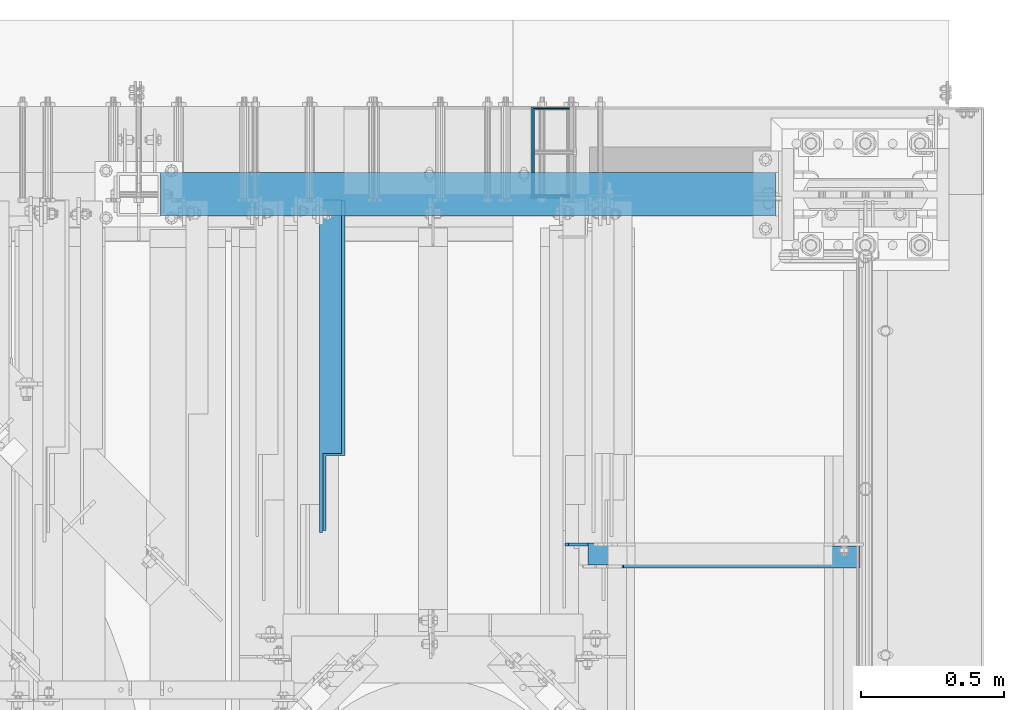
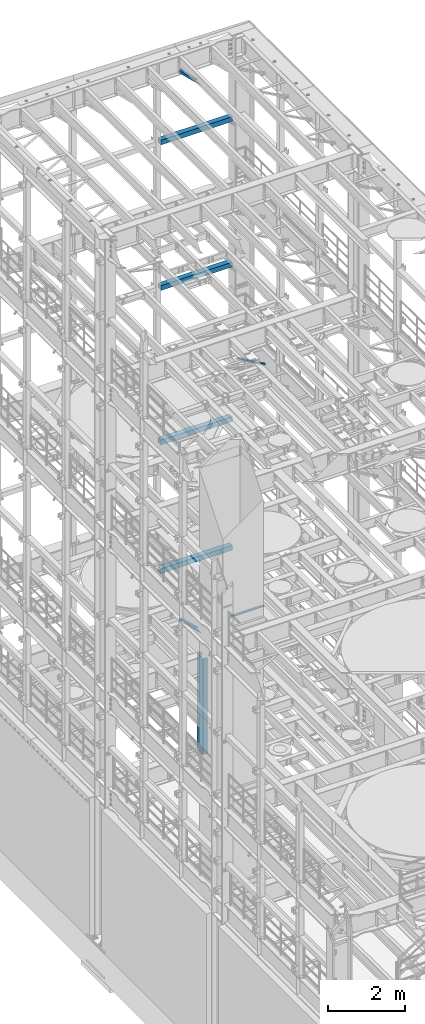
# One storey, part 1070 of 1876: 9 beams, 1 member, 10 elements without a shape of their own.
"""IFC2X3 building model written with IfcOpenShell, lengths in millimetres."""

from ifc_helpers import new_model, si_unit, frame, origin_with_axes, place, context, subcontext, project, spatial, faceted_brep, material, type_object, element, aggregate, save


model = new_model("IFC2X3")

# Units and contexts
model_context = context("Model", 3, precision=1e-05, world=origin_with_axes())
body_context = subcontext(model_context, "Body", "Model", "MODEL_VIEW")
ifc_project = project(units=[si_unit("LENGTHUNIT", "METRE", prefix="MILLI"), si_unit("AREAUNIT", "SQUARE_METRE"), si_unit("VOLUMEUNIT", "CUBIC_METRE"), si_unit("MASSUNIT", "GRAM", prefix="KILO"), si_unit("TIMEUNIT", "SECOND"), si_unit("PLANEANGLEUNIT", "RADIAN"), si_unit("SOLIDANGLEUNIT", "STERADIAN"), si_unit("THERMODYNAMICTEMPERATUREUNIT", "DEGREE_CELSIUS"), si_unit("LUMINOUSINTENSITYUNIT", "LUMEN")], contexts=[model_context])

# Site, building, storey
site_placement = place(None, origin_with_axes())
site = spatial("IfcSite", under=ifc_project, at=site_placement, CompositionType="ELEMENT")
building_placement = place(site_placement, origin_with_axes())
building = spatial("IfcBuilding", under=site, at=building_placement, Name="Undefined", CompositionType="ELEMENT")
storey_placement = place(building_placement, origin_with_axes())
storey = spatial("IfcBuildingStorey", under=building, at=storey_placement, Name="Undefined", CompositionType="ELEMENT", Elevation=0.0)

# Assembly, beam
assembly_1_placement = place(storey_placement, origin_with_axes())
assembly_1 = element("IfcElementAssembly", 1, at=assembly_1_placement, inside=storey, Name="FRAME", AssemblyPlace="NOTDEFINED", PredefinedType="RIGID_FRAME")
ifc_material_1 = material()
beam_type_1 = type_object("IfcBeamType", Name="HSS6X6X3/8", PredefinedType="NOTDEFINED")
beam_1_placement = place(assembly_1_placement, frame((5080.0, 13716.0, 6330.95), z_axis=(0.0, 1.0, 0.0), x_axis=(1.0, 0.0, 0.0)))
beam_1 = element("IfcBeam", 2, at=beam_1_placement, type_object=beam_type_1, material=ifc_material_1, Name="BEAM", ObjectType="HSS6X6X3/8", context=body_context, shape_type="Brep", body=[
    faceted_brep([(76.2000000000007, 66.6749999999993, -66.6750000000002), (76.2000000000007, -66.6749999999993, -66.6750000000002), (2225.675, -66.6750000000002, -66.6749999999993), (2225.675, 66.6750000000002, -66.6749999999993), (76.2000000000007, -66.6749999999993, 66.6750000000002), (2225.675, -66.6750000000002, 66.6749999999993), (76.2000000000007, 66.6749999999993, 66.6750000000002), (2225.675, 66.6750000000002, 66.6749999999993), (76.2000000000007, 76.2000000000007, -76.1999999999998), (76.2000000000007, 76.2000000000007, 76.1999999999998), (2225.675, 76.1999999999998, 76.2000000000007), (2225.675, 76.1999999999998, -76.2000000000007), (76.2000000000007, -76.2000000000007, 76.1999999999998), (2225.675, -76.1999999999998, 76.2000000000007), (76.2000000000007, -76.2000000000007, -76.1999999999998), (2225.675, -76.1999999999998, -76.2000000000007)], [[[0, 1, 2, 3]], [[1, 4, 5, 2]], [[4, 6, 7, 5]], [[6, 0, 3, 7]], [[8, 9, 10, 11]], [[9, 12, 13, 10]], [[12, 14, 15, 13]], [[14, 8, 11, 15]], [[13, 15, 11, 10], [5, 7, 3, 2]], [[14, 12, 9, 8], [6, 4, 1, 0]]]),
])
aggregate(assembly_1, [beam_1])

assembly_2_placement = place(storey_placement, origin_with_axes())
assembly_2 = element("IfcElementAssembly", 3, at=assembly_2_placement, inside=storey, Name="FRAME", AssemblyPlace="NOTDEFINED", PredefinedType="RIGID_FRAME")
beam_2_placement = place(assembly_2_placement, frame((5080.0, 13716.0, 19958.05), z_axis=(0.0, 1.0, 0.0), x_axis=(1.0, 0.0, 0.0)))
beam_2 = element("IfcBeam", 4, at=beam_2_placement, type_object=beam_type_1, material=ifc_material_1, Name="BEAM", ObjectType="HSS6X6X3/8", context=body_context, shape_type="Brep", body=[
    faceted_brep([(76.2000000000007, 66.6749999999993, -66.6750000000002), (76.2000000000007, -66.6749999999993, -66.6750000000002), (2225.675, -66.6750000000002, -66.6749999999993), (2225.675, 66.6750000000002, -66.6749999999993), (76.2000000000007, -66.6749999999993, 66.6750000000002), (2225.675, -66.6750000000002, 66.6749999999993), (76.2000000000007, 66.6749999999993, 66.6750000000002), (2225.675, 66.6750000000002, 66.6749999999993), (76.2000000000007, 76.2000000000007, -76.1999999999998), (76.2000000000007, 76.2000000000007, 76.1999999999998), (2225.675, 76.1999999999998, 76.2000000000007), (2225.675, 76.1999999999998, -76.2000000000007), (76.2000000000007, -76.2000000000007, 76.1999999999998), (2225.675, -76.1999999999998, 76.2000000000007), (76.2000000000007, -76.2000000000007, -76.1999999999998), (2225.675, -76.1999999999998, -76.2000000000007)], [[[0, 1, 2, 3]], [[1, 4, 5, 2]], [[4, 6, 7, 5]], [[6, 0, 3, 7]], [[8, 9, 10, 11]], [[9, 12, 13, 10]], [[12, 14, 15, 13]], [[14, 8, 11, 15]], [[13, 15, 11, 10], [5, 7, 3, 2]], [[14, 12, 9, 8], [6, 4, 1, 0]]]),
])
aggregate(assembly_2, [beam_2])

assembly_3_placement = place(storey_placement, origin_with_axes())
assembly_3 = element("IfcElementAssembly", 5, at=assembly_3_placement, inside=storey, Name="FRAME", AssemblyPlace="NOTDEFINED", PredefinedType="RIGID_FRAME")
beam_3_placement = place(assembly_3_placement, frame((5080.0, 13716.0, 15335.25), z_axis=(0.0, 1.0, 0.0), x_axis=(1.0, 0.0, 0.0)))
beam_3 = element("IfcBeam", 6, at=beam_3_placement, type_object=beam_type_1, material=ifc_material_1, Name="BEAM", ObjectType="HSS6X6X3/8", context=body_context, shape_type="Brep", body=[
    faceted_brep([(76.2000000000007, 66.6749999999993, -66.6750000000002), (76.2000000000007, -66.6749999999993, -66.6750000000002), (2225.675, -66.6750000000002, -66.6749999999993), (2225.675, 66.6750000000002, -66.6749999999993), (76.2000000000007, -66.6749999999993, 66.6750000000002), (2225.675, -66.6750000000002, 66.6749999999993), (76.2000000000007, 66.6749999999993, 66.6750000000002), (2225.675, 66.6750000000002, 66.6749999999993), (76.2000000000007, 76.2000000000007, -76.1999999999998), (76.2000000000007, 76.2000000000007, 76.1999999999998), (2225.675, 76.1999999999998, 76.2000000000007), (2225.675, 76.1999999999998, -76.2000000000007), (76.2000000000007, -76.2000000000007, 76.1999999999998), (2225.675, -76.1999999999998, 76.2000000000007), (76.2000000000007, -76.2000000000007, -76.1999999999998), (2225.675, -76.1999999999998, -76.2000000000007)], [[[0, 1, 2, 3]], [[1, 4, 5, 2]], [[4, 6, 7, 5]], [[6, 0, 3, 7]], [[8, 9, 10, 11]], [[9, 12, 13, 10]], [[12, 14, 15, 13]], [[14, 8, 11, 15]], [[13, 15, 11, 10], [5, 7, 3, 2]], [[14, 12, 9, 8], [6, 4, 1, 0]]]),
])
aggregate(assembly_3, [beam_3])

assembly_4_placement = place(storey_placement, origin_with_axes())
assembly_4 = element("IfcElementAssembly", 7, at=assembly_4_placement, inside=storey, Name="FRAME", AssemblyPlace="NOTDEFINED", PredefinedType="RIGID_FRAME")
beam_4_placement = place(assembly_4_placement, frame((5080.0, 13716.0, 10420.35), z_axis=(0.0, 1.0, 0.0), x_axis=(1.0, 0.0, 0.0)))
beam_4 = element("IfcBeam", 8, at=beam_4_placement, type_object=beam_type_1, material=ifc_material_1, Name="BEAM", ObjectType="HSS6X6X3/8", context=body_context, shape_type="Brep", body=[
    faceted_brep([(76.2000000000007, 66.6749999999993, -66.6750000000002), (76.2000000000007, -66.6749999999993, -66.6750000000002), (2225.675, -66.6750000000002, -66.6749999999993), (2225.675, 66.6750000000002, -66.6749999999993), (76.2000000000007, -66.6749999999993, 66.6750000000002), (2225.675, -66.6750000000002, 66.6749999999993), (76.2000000000007, 66.6749999999993, 66.6750000000002), (2225.675, 66.6750000000002, 66.6749999999993), (76.2000000000007, 76.2000000000007, -76.1999999999998), (76.2000000000007, 76.2000000000007, 76.1999999999998), (2225.675, 76.1999999999998, 76.2000000000007), (2225.675, 76.1999999999998, -76.2000000000007), (76.2000000000007, -76.2000000000007, 76.1999999999998), (2225.675, -76.1999999999998, 76.2000000000007), (76.2000000000007, -76.2000000000007, -76.1999999999998), (2225.675, -76.1999999999998, -76.2000000000007)], [[[0, 1, 2, 3]], [[1, 4, 5, 2]], [[4, 6, 7, 5]], [[6, 0, 3, 7]], [[8, 9, 10, 11]], [[9, 12, 13, 10]], [[12, 14, 15, 13]], [[14, 8, 11, 15]], [[13, 15, 11, 10], [5, 7, 3, 2]], [[14, 12, 9, 8], [6, 4, 1, 0]]]),
])
aggregate(assembly_4, [beam_4])

# Assembly, member
assembly_5_placement = place(storey_placement, origin_with_axes())
assembly_5 = element("IfcElementAssembly", 9, at=assembly_5_placement, inside=storey, Name="BRACE", AssemblyPlace="NOTDEFINED", PredefinedType="RIGID_FRAME")
ifc_material_2 = material(Name="STEEL/A36")
member_type = type_object("IfcMemberType", Name="L3X3X3/8", PredefinedType="NOTDEFINED")
member_placement = place(assembly_5_placement, frame((6673.56288393271, 12449.175, 13302.1718727092), z_axis=(0.0, -1.0, 0.0), x_axis=(0.861630637805759, 0.0, -0.507535854885584)))
member = element("IfcMember", 10, at=member_placement, type_object=member_type, material=ifc_material_2, Name="BRACE", ObjectType="L3X3X3/8", context=body_context, shape_type="Brep", body=[
    faceted_brep([(93.8357350541173, 38.0999999999913, -38.0999999999999), (93.8357350541173, 38.0999999999913, 38.0999999999999), (1052.95263444459, 38.0999999997257, 38.0999999999999), (1052.95263444459, 38.0999999997257, -38.0999999999999), (93.8357350541228, 28.5749999999862, 38.0999999999999), (1052.95263444459, 28.5749999997206, 38.0999999999999), (93.8357350541228, 28.5749999999862, -28.5749999999998), (1052.95263444459, 28.5749999997206, -28.5749999999998), (93.8357350541537, -38.100000000044, -28.5749999999998), (1052.95263444462, -38.100000000306, -28.5749999999998), (93.8357350541537, -38.100000000044, -38.0999999999999), (1052.95263444462, -38.100000000306, -38.0999999999999)], [[[0, 1, 2, 3]], [[1, 4, 5, 2]], [[4, 6, 7, 5]], [[6, 8, 9, 7]], [[8, 10, 11, 9]], [[10, 0, 3, 11]], [[5, 7, 9, 11, 3, 2]], [[10, 8, 6, 4, 1, 0]]]),
])
aggregate(assembly_5, [member])

# Assembly, beam
assembly_6_placement = place(storey_placement, origin_with_axes())
assembly_6 = element("IfcElementAssembly", 11, at=assembly_6_placement, inside=storey, AssemblyPlace="NOTDEFINED", PredefinedType="RIGID_FRAME")
beam_type_2 = type_object("IfcBeamType", Name="L3X3X3/8", PredefinedType="NOTDEFINED")
beam_5_placement = place(assembly_6_placement, frame((5762.62500009537, 12830.5843372416, 4789.15168871849), z_axis=(1.0, 0.0, 0.0), x_axis=(0.0, 0.967147277703794, -0.254216724922142)))
beam_5 = element("IfcBeam", 12, at=beam_5_placement, type_object=beam_type_2, material=ifc_material_2, ObjectType="L3X3X3/8", context=body_context, shape_type="Brep", body=[
    faceted_brep([(0.0, 38.1000000000004, -38.1), (0.0, 38.1000000000004, 38.1), (881.684520949349, 38.1000000001804, 38.1000000000004), (881.684520949349, 38.1000000001804, -38.1000000000004), (-36.2371036914428, 28.5749999999935, 38.1000000000004), (881.696433462228, 28.5750000001808, 38.1000000000004), (-36.2371036914428, 28.5749999999935, -28.5749999999998), (881.696433462228, 28.5750000001808, -28.5749999999998), (-289.896829504256, -38.1000000000595, -28.5749999999998), (881.779821052378, -38.0999999998203, -28.5749999999998), (-289.896829504256, -38.1000000000595, -38.1000000000004), (881.779821052378, -38.0999999998203, -38.1000000000004)], [[[0, 1, 2, 3]], [[1, 4, 5, 2]], [[4, 6, 7, 5]], [[6, 8, 9, 7]], [[8, 10, 11, 9]], [[10, 0, 3, 11]], [[5, 7, 9, 11, 3, 2]], [[10, 8, 6, 4, 1, 0]]]),
])
aggregate(assembly_6, [beam_5])

assembly_7_placement = place(storey_placement, origin_with_axes())
assembly_7 = element("IfcElementAssembly", 13, at=assembly_7_placement, inside=storey, AssemblyPlace="NOTDEFINED", PredefinedType="RIGID_FRAME")
beam_6_placement = place(assembly_7_placement, frame((5749.925, 12840.8509533049, 22213.431722183), z_axis=(1.0, 0.0, 0.0), x_axis=(0.0, 0.970296005691371, -0.241920774923053)))
beam_6 = element("IfcBeam", 14, at=beam_6_placement, type_object=beam_type_2, material=ifc_material_2, ObjectType="L3X3X3/8", context=body_context, shape_type="Brep", body=[
    faceted_brep([(0.0, 38.1000000000004, -38.1), (0.0, 38.1000000000004, 38.1), (871.989692018896, 38.1000000003733, 38.1000000000004), (871.989692018896, 38.1000000003733, -38.1000000000004), (-38.2028763666676, 28.5750000000298, 38.1000000000004), (871.9896920189, 28.5750000003572, 38.1000000000004), (-38.2028763666676, 28.5750000000298, -28.5749999999998), (871.9896920189, 28.5750000003572, -28.5749999999998), (-305.623010913256, -38.1000000001623, -28.5749999999998), (871.989692018928, -38.0999999997366, -28.5749999999998), (-305.623010913256, -38.1000000001623, -38.1000000000004), (871.989692018928, -38.0999999997366, -38.1000000000004)], [[[0, 1, 2, 3]], [[1, 4, 5, 2]], [[4, 6, 7, 5]], [[6, 8, 9, 7]], [[8, 10, 11, 9]], [[10, 0, 3, 11]], [[5, 7, 9, 11, 3, 2]], [[10, 8, 6, 4, 1, 0]]]),
])
aggregate(assembly_7, [beam_6])

assembly_8_placement = place(storey_placement, origin_with_axes())
assembly_8 = element("IfcElementAssembly", 15, at=assembly_8_placement, inside=storey, Name="ANGLE", AssemblyPlace="NOTDEFINED", PredefinedType="RIGID_FRAME")
beam_7_placement = place(assembly_8_placement, frame((6565.9, 12458.7, 5092.7), z_axis=(0.0, -1.0, 0.0), x_axis=(1.0, 0.0, 0.0)))
beam_7 = element("IfcBeam", 16, at=beam_7_placement, type_object=beam_type_2, material=ifc_material_2, Name="ANGLE", ObjectType="L3X3X3/8", context=body_context, shape_type="Brep", body=[
    faceted_brep([(938.213000419482, 28.5750000000007, -28.5749999999998), (938.213001286278, 28.5750000000007, 38.0999999999999), (84.137014014791, 28.5749999999998, 38.1000000000258), (84.1370001605219, 28.5749999999998, -28.5750000000007), (938.213001286278, 38.0999999999985, 38.0999999999999), (84.136999759924, 38.0999999999985, 38.0999999999999), (15.8750004498515, 25.4000000000005, -28.5750000000007), (15.8750002879233, 25.4000000000005, -38.1000000000004), (3.17500047865815, 12.7000001907354, -38.1000000000004), (3.1750006405864, 12.7000001907354, -28.5750000000007), (84.1369986264262, 25.4000000000005, -28.5750000000007), (84.136998464498, 25.4000000000005, -38.1000000000004), (84.1369984645207, 38.0999999999985, -38.0999999999999), (938.213000295654, 38.0999999999985, -38.0999999999999), (938.213000419482, 12.6999992370475, -28.5749999999998), (938.213000295654, 12.6999992370475, -38.0999999999999), (1015.20625603472, 12.6999992370475, -28.5749999999998), (1015.20625591089, 12.6999992370475, -38.0999999999999), (1046.95625603472, -19.0500007629525, -28.5749999999998), (1046.95625591089, -19.0500007629525, -38.0999999999999), (1046.95625011747, -38.0999999999985, -28.5749999999998), (1046.95625011747, -38.0999999999985, -38.0999999999999), (3.17499999075153, -38.0999999999985, -28.5749999999998), (3.17499999075153, -38.0999999999985, -38.0999999999999), (3.17500047865815, -1.52587836055318e-06, -38.1000000000004), (3.1750006405864, -1.52587836055318e-06, -28.5750000000007)], [[[0, 1, 2, 3]], [[1, 4, 5, 2]], [[6, 7, 8, 9]], [[10, 11, 7, 6]], [[2, 5, 12, 11, 10, 3]], [[4, 13, 12, 5]], [[1, 0, 14, 15, 13, 4]], [[16, 17, 15, 14]], [[17, 16, 18, 19]], [[19, 18, 20, 21]], [[22, 23, 21, 20]], [[8, 7, 11, 12, 13, 15, 17, 19, 21, 23, 24]], [[9, 8, 24, 25]], [[20, 18, 16, 14, 0, 3, 10, 6, 9, 25, 22]], [[24, 23, 22, 25]]]),
])
aggregate(assembly_8, [beam_7])

assembly_9_placement = place(storey_placement, origin_with_axes())
assembly_9 = element("IfcElementAssembly", 17, at=assembly_9_placement, inside=storey, Name="BEAM", AssemblyPlace="NOTDEFINED", PredefinedType="REINFORCEMENT_UNIT")
ifc_material_3 = material(Name="CONCRETE/5000")
beam_type_3 = type_object("IfcBeamType", PredefinedType="NOTDEFINED")
beam_8_placement = place(assembly_9_placement, frame((6584.95045001539, 13713.6189938963, 1524.0), z_axis=(0.0, 0.0, 1.0), x_axis=(-1.0, 0.0, 0.0)))
beam_8 = element("IfcBeam", 18, at=beam_8_placement, type_object=beam_type_3, material=ifc_material_3, Name="BEAM", context=body_context, shape_type="Brep", body=[
    faceted_brep([(1.60071067512035e-10, -2.38100000000122, -1524.0), (1.60071067512035e-10, -2.38100000000122, 1524.0), (-1.60071067512035e-10, 2.38099999999758, 1524.0), (-1.60071067512035e-10, 2.38099999999758, -1524.0), (126.999998724466, 2.3810000085341, 1524.0), (126.999998724466, 2.3810000085341, -1524.0), (122.237998962564, -2.38099999178485, -1524.0), (122.237998962564, -2.38099999178485, 1524.0), (127.000013964417, -302.417987546485, 1524.0), (127.000013964417, -302.417987546485, -1524.0), (122.238013726317, -297.655987784585, -1524.0), (122.238013726317, -297.655987784585, 1524.0), (1.50022988236742e-05, -302.417993896486, 1524.0), (1.50022988236742e-05, -302.417993896486, -1524.0), (1.47641985677183e-05, -297.655993896486, 1524.0), (1.47641985677183e-05, -297.655993896486, -1524.0)], [[[0, 1, 2, 3]], [[3, 2, 4, 5]], [[1, 0, 6, 7]], [[5, 4, 8, 9]], [[7, 6, 10, 11]], [[9, 8, 12, 13]], [[8, 4, 2, 1, 7, 11, 14, 12]], [[11, 10, 15, 14]], [[10, 6, 0, 3, 5, 9, 13, 15]], [[14, 15, 13, 12]]]),
])
aggregate(assembly_9, [beam_8])

assembly_10_placement = place(storey_placement, origin_with_axes())
assembly_10 = element("IfcElementAssembly", 19, at=assembly_10_placement, inside=storey, Name="BENT PLATE", AssemblyPlace="NOTDEFINED", PredefinedType="RIGID_FRAME")
beam_type_4 = type_object("IfcBeamType", PredefinedType="NOTDEFINED")
beam_9_placement = place(assembly_10_placement, frame((6584.9504498965, 13706.4754938963, 1524.0), z_axis=(0.0, 0.0, 1.0), x_axis=(-1.0, 0.0, 0.0)))
beam_9 = element("IfcBeam", 20, at=beam_9_placement, type_object=beam_type_4, material=ifc_material_2, Name="BENT PLATE", context=body_context, shape_type="Brep", body=[
    faceted_brep([(9.877112461254e-10, -3.17499999999563, -1524.0), (9.877112461254e-10, -3.17499999999563, 1524.0), (-9.88620740827173e-10, 3.17500000000291, 1524.0), (-9.88620740827173e-10, 3.17500000000291, -1524.0), (133.349999999999, 3.17499999999927, 1524.0), (133.349999999999, 3.17499999999927, -1524.0), (126.999999999999, -3.17499999999927, -1524.0), (126.999999999999, -3.17499999999927, 1524.0), (133.349999999999, -315.911474609373, 1524.0), (133.349999999999, -315.911474609373, -1524.0), (126.999999999999, -309.561474609374, -1524.0), (126.999999999999, -309.561474609374, 1524.0), (-2.37773747358005e-07, -315.911474609373, 1524.0), (-2.37773747358005e-07, -315.911474609373, -1524.0), (-2.37773747358005e-07, -309.561474609374, 1524.0), (-2.37773747358005e-07, -309.561474609374, -1524.0)], [[[0, 1, 2, 3]], [[3, 2, 4, 5]], [[1, 0, 6, 7]], [[5, 4, 8, 9]], [[7, 6, 10, 11]], [[9, 8, 12, 13]], [[8, 4, 2, 1, 7, 11, 14, 12]], [[11, 10, 15, 14]], [[10, 6, 0, 3, 5, 9, 13, 15]], [[14, 15, 13, 12]]]),
])
aggregate(assembly_10, [beam_9])

save(model, "model.ifc")
